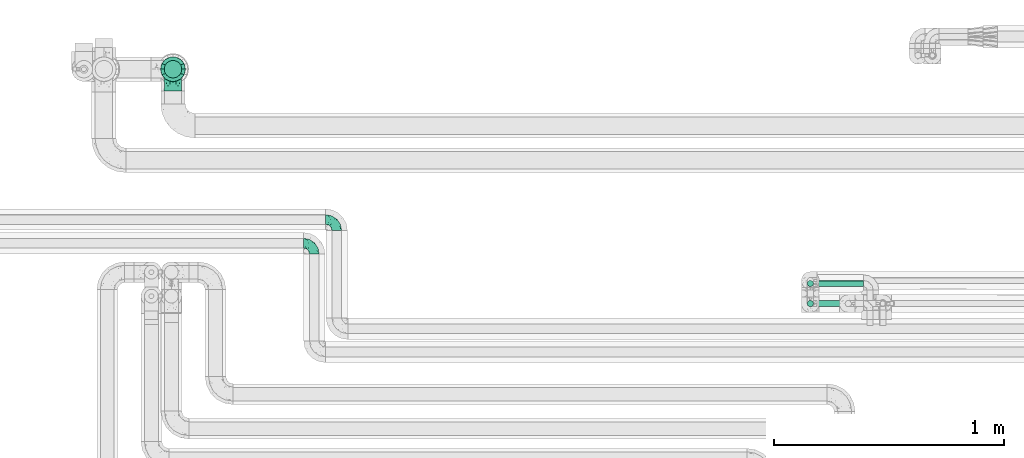
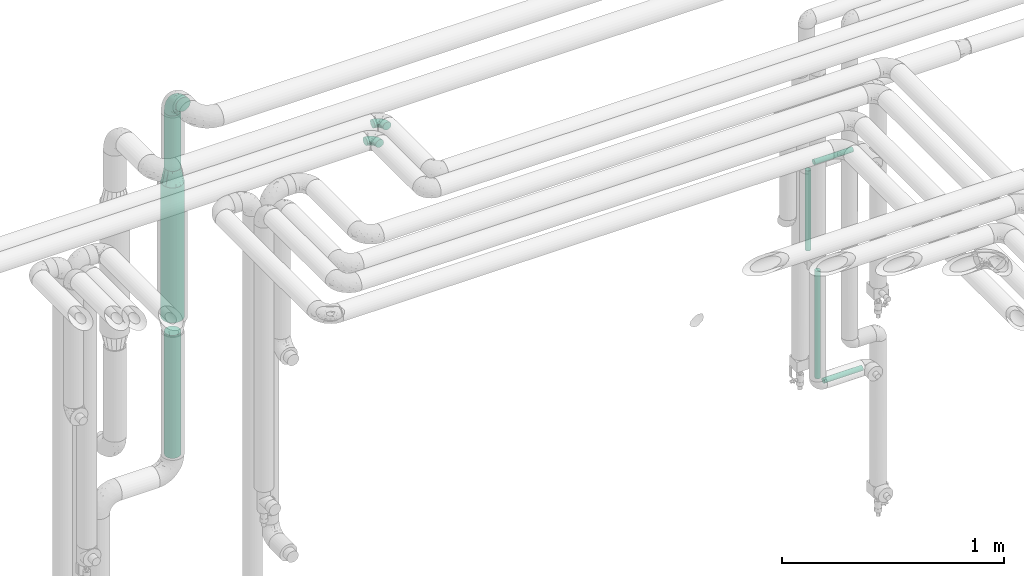
# One storey, part 644 of 827: 7 flow segments, 4 flow fittings.
"""IFC2X3 building model written with IfcOpenShell, lengths in millimetres."""

from ifc_helpers import new_model, entity, si_unit, converted_unit, derived_unit, direction, frame, origin, origin_2d_with_axis, place, context, subcontext, project, spatial, circle, extrude, faceted_brep, source, transform, mapped, material, type_object, type_shapes, element, save


model = new_model("IFC2X3")

# Units and contexts
model_context = context("Model", 3, precision=0.01, world=origin(), true_north=direction((6.12303176911189e-17, 1.0)))
body_context = subcontext(model_context, "Body", "Model", "MODEL_VIEW")
ifc_project = project(units=[si_unit("LENGTHUNIT", "METRE", prefix="MILLI"), si_unit("AREAUNIT", "SQUARE_METRE"), si_unit("VOLUMEUNIT", "CUBIC_METRE"), converted_unit("PLANEANGLEUNIT", "DEGREE", entity("IfcRatioMeasure", 0.0174532925199433), si_unit("PLANEANGLEUNIT", "RADIAN"), dimensions=[0, 0, 0, 0, 0, 0, 0]), si_unit("MASSUNIT", "GRAM", prefix="KILO"), derived_unit("MASSDENSITYUNIT", [(si_unit("MASSUNIT", "GRAM", prefix="KILO"), 1), (si_unit("LENGTHUNIT", "METRE"), -3)]), derived_unit("MOMENTOFINERTIAUNIT", [(si_unit("LENGTHUNIT", "METRE"), 4)]), si_unit("TIMEUNIT", "SECOND"), si_unit("FREQUENCYUNIT", "HERTZ"), si_unit("THERMODYNAMICTEMPERATUREUNIT", "DEGREE_CELSIUS"), derived_unit("THERMALTRANSMITTANCEUNIT", [(si_unit("MASSUNIT", "GRAM", prefix="KILO"), 1), (si_unit("THERMODYNAMICTEMPERATUREUNIT", "KELVIN"), -1), (si_unit("TIMEUNIT", "SECOND"), -3)]), derived_unit("VOLUMETRICFLOWRATEUNIT", [(si_unit("LENGTHUNIT", "METRE"), 3), (si_unit("TIMEUNIT", "SECOND"), -1)]), derived_unit("MASSFLOWRATEUNIT", [(si_unit("MASSUNIT", "GRAM", prefix="KILO"), 1), (si_unit("TIMEUNIT", "SECOND"), -1)]), derived_unit("ROTATIONALFREQUENCYUNIT", [(si_unit("TIMEUNIT", "SECOND"), -1)]), si_unit("ELECTRICCURRENTUNIT", "AMPERE"), si_unit("ELECTRICVOLTAGEUNIT", "VOLT"), si_unit("POWERUNIT", "WATT"), si_unit("FORCEUNIT", "NEWTON", prefix="KILO"), si_unit("ILLUMINANCEUNIT", "LUX"), si_unit("LUMINOUSFLUXUNIT", "LUMEN"), si_unit("LUMINOUSINTENSITYUNIT", "CANDELA"), derived_unit("USERDEFINED", [(si_unit("MASSUNIT", "GRAM", prefix="KILO"), -1), (si_unit("LENGTHUNIT", "METRE"), -2), (si_unit("TIMEUNIT", "SECOND"), 3), (si_unit("LUMINOUSFLUXUNIT", "LUMEN"), 1)]), derived_unit("LINEARVELOCITYUNIT", [(si_unit("LENGTHUNIT", "METRE"), 1), (si_unit("TIMEUNIT", "SECOND"), -1)]), si_unit("PRESSUREUNIT", "PASCAL"), derived_unit("USERDEFINED", [(si_unit("LENGTHUNIT", "METRE"), -2), (si_unit("MASSUNIT", "GRAM", prefix="KILO"), 1), (si_unit("TIMEUNIT", "SECOND"), -2)]), derived_unit("LINEARFORCEUNIT", [(si_unit("MASSUNIT", "GRAM", prefix="KILO"), 1), (si_unit("LENGTHUNIT", "METRE"), 1), (si_unit("TIMEUNIT", "SECOND"), -2), (si_unit("LENGTHUNIT", "METRE"), -1)]), derived_unit("PLANARFORCEUNIT", [(si_unit("MASSUNIT", "GRAM", prefix="KILO"), 1), (si_unit("LENGTHUNIT", "METRE"), 1), (si_unit("TIMEUNIT", "SECOND"), -2), (si_unit("LENGTHUNIT", "METRE"), -2)])], contexts=[model_context])

# Site, building, storey
site_placement = place(None, origin())
site = spatial("IfcSite", under=ifc_project, at=site_placement, CompositionType="ELEMENT")
building_placement = place(site_placement, origin())
building = spatial("IfcBuilding", under=site, at=building_placement, CompositionType="ELEMENT")
storey_placement = place(building_placement, frame((0.0, 0.0, 28200.0)))
storey = spatial("IfcBuildingStorey", under=building, at=storey_placement, Name="08", CompositionType="ELEMENT", Elevation=28200.0)

# Flow segments
pipe_segment_type_1 = type_object("IfcPipeSegmentType", PredefinedType="NOTDEFINED")
flow_segment_1_placement = place(storey_placement, frame((31716.11, 19313.84, 2600.0)))
element("IfcFlowSegment", 1, at=flow_segment_1_placement, inside=storey, type_object=pipe_segment_type_1, context=body_context, shape_type="SweptSolid", body=[
    extrude(circle(Radius=38.0, at=origin_2d_with_axis()), frame((39.6, 39.6, 0.0)), (0.0, 0.0, 1.0), 305.000000000013),
])
flow_segment_2_placement = place(storey_placement, frame((31716.31, 19313.84, 1020.26)))
element("IfcFlowSegment", 2, at=flow_segment_2_placement, inside=storey, type_object=pipe_segment_type_1, context=body_context, shape_type="SweptSolid", body=[
    extrude(circle(Radius=38.0, at=origin_2d_with_axis()), frame((39.6, 39.6, 0.0), z_axis=(0.0, 0.0, 1.0), x_axis=(-1.0, 0.0, 0.0)), (0.0, 0.0, 1.0), 676.738359999959),
])
flow_segment_3_placement = place(storey_placement, frame((31700.11, 19297.84, 1777.0)))
element("IfcFlowSegment", 3, at=flow_segment_3_placement, inside=storey, type_object=pipe_segment_type_1, context=body_context, shape_type="SweptSolid", body=[
    extrude(circle(Radius=54.0, at=origin_2d_with_axis()), frame((55.6, 55.6, 0.0), z_axis=(0.0, 0.0, 1.0), x_axis=(-1.0, 0.0, 0.0)), (0.0, 0.0, 1.0), 743.000000000004),
])
pipe_segment_type_2 = type_object("IfcPipeSegmentType", PredefinedType="NOTDEFINED")
flow_segment_4_placement = place(storey_placement, frame((34510.39, 18319.92, 1089.1)))
element("IfcFlowSegment", 4, at=flow_segment_4_placement, inside=storey, type_object=pipe_segment_type_2, context=body_context, shape_type="SweptSolid", body=[
    extrude(circle(Radius=13.4, at=origin_2d_with_axis()), frame((15.0, 15.0, 0.0)), (0.0, 0.0, 1.0), 591.900000000008),
])
flow_segment_5_placement = place(storey_placement, frame((34554.49, 18319.92, 1045.0)))
element("IfcFlowSegment", 5, at=flow_segment_5_placement, inside=storey, type_object=pipe_segment_type_2, context=body_context, shape_type="SweptSolid", body=[
    extrude(circle(Radius=13.4, at=origin_2d_with_axis()), frame((0.0, 15.0, 15.0), z_axis=(1.0, 0.0, 0.0), x_axis=(0.0, -1.0, 0.0)), (0.0, 0.0, 1.0), 201.799999999997),
])
flow_segment_6_placement = place(storey_placement, frame((34554.49, 18406.91, 2195.0)))
element("IfcFlowSegment", 6, at=flow_segment_6_placement, inside=storey, type_object=pipe_segment_type_2, context=body_context, shape_type="SweptSolid", body=[
    extrude(circle(Radius=13.4, at=origin_2d_with_axis()), frame((0.0, 15.0, 15.0), z_axis=(1.0, 0.0, 0.0), x_axis=(0.0, 1.0, 0.0)), (0.0, 0.0, 1.0), 201.799999999997),
])
flow_segment_7_placement = place(storey_placement, frame((34510.39, 18406.91, 1739.1)))
element("IfcFlowSegment", 7, at=flow_segment_7_placement, inside=storey, type_object=pipe_segment_type_2, context=body_context, shape_type="SweptSolid", body=[
    extrude(circle(Radius=13.4, at=origin_2d_with_axis()), frame((15.0, 15.0, 0.0)), (0.0, 0.0, 1.0), 441.800000000021),
])

# Flow fittings
ifc_material = material()
pipe_fitting_type_1 = type_object("IfcPipeFittingType", Name="ADSK_1", PredefinedType="NOTDEFINED", material=ifc_material)
shared_shape_1 = source(origin(), body_context, "Body", "Brep", [
    faceted_brep([(-48.0, 10.6, -18.36), (-48.0, 5.49, -20.48), (-48.0, 0.0, -21.2), (-48.0, -5.49, -20.48), (-48.0, -10.6, -18.36), (-48.0, -14.99, -14.99), (-48.0, -18.36, -10.6), (-48.0, -20.48, -5.49), (-48.0, -21.2, 0.0), (-48.0, -20.48, 5.49), (-48.0, -18.36, 10.6), (-48.0, -14.99, 14.99), (-48.0, -10.6, 18.36), (-48.0, -5.49, 20.48), (-48.0, 0.0, 21.2), (-48.0, 5.49, 20.48), (-48.0, 10.6, 18.36), (-48.0, 14.99, 14.99), (-48.0, 18.36, 10.6), (-48.0, 20.48, 5.49), (-48.0, 21.2, 0.0), (-48.0, 20.48, -5.49), (-48.0, 18.36, -10.6), (-48.0, 14.99, -14.99), (0.0, 48.0, -21.2), (-5.49, 48.0, -20.48), (-10.6, 48.0, -18.36), (-14.99, 48.0, -14.99), (-18.36, 48.0, -10.6), (-20.48, 48.0, -5.49), (-21.2, 48.0, 0.0), (-20.48, 48.0, 5.49), (-18.36, 48.0, 10.6), (-14.99, 48.0, 14.99), (-10.6, 48.0, 18.36), (-5.49, 48.0, 20.48), (0.0, 48.0, 21.2), (5.49, 48.0, 20.48), (10.6, 48.0, 18.36), (14.99, 48.0, 14.99), (18.36, 48.0, 10.6), (20.48, 48.0, 5.49), (21.2, 48.0, 0.0), (20.48, 48.0, -5.49), (18.36, 48.0, -10.6), (14.99, 48.0, -14.99), (10.6, 48.0, -18.36), (5.49, 48.0, -20.48), (-35.25, -16.22, 12.01), (-34.76, -18.57, 0.0), (-20.87, -12.37, 10.9), (-31.49, -11.78, 15.9), (-37.0, -2.58, 20.86), (-33.89, 3.62, 21.15), (-31.81, -18.14, 6.76), (-5.78, 5.78, 17.67), (-19.42, -4.1, 17.86), (-9.6, -3.39, 13.73), (-35.44, -7.73, 19.13), (11.78, 31.49, 15.9), (-5.93, -5.46, 6.95), (-18.45, -13.78, 5.46), (-10.29, -8.43, 0.0), (-24.6, 0.55, 20.62), (-37.28, 17.94, 13.81), (-33.38, 22.85, 9.59), (-41.46, 20.06, 8.75), (-29.51, 20.45, 15.16), (-15.04, 10.79, 21.13), (-7.08, 16.98, 20.93), (-8.39, 23.51, 21.15), (-40.86, 13.03, 17.26), (-8.05, 41.26, 19.83), (-3.21, 35.97, 21.14), (8.53, 19.66, 14.74), (4.1, 19.42, 17.86), (-37.72, 22.66, 4.78), (-37.07, 8.58, 19.98), (-13.0, 5.43, 19.97), (-3.78, 13.93, 19.7), (3.02, 8.69, 13.43), (-2.27, -0.05, 10.65), (6.22, 6.99, 7.09), (-22.25, 34.6, 9.45), (18.14, 31.81, 6.76), (16.22, 35.25, 12.01), (12.37, 20.87, 10.9), (7.73, 35.44, 19.13), (-21.52, -15.93, 0.0), (2.58, 37.0, 20.86), (18.57, 34.76, 0.0), (13.78, 18.45, 5.46), (15.93, 21.52, 0.0), (-20.03, -8.54, 14.9), (-28.6, 28.6, 5.16), (-24.79, 34.6, 0.0), (-34.6, 24.79, 0.0), (-22.81, 37.41, 4.68), (-23.36, 26.33, 14.79), (-13.68, 37.05, 17.49), (-17.72, 38.12, 13.73), (-26.25, 27.3, 11.24), (-9.71, 32.34, 20.14), (-17.26, 25.6, 18.71), (-26.33, 9.99, 20.77), (-24.06, 6.05, 21.2), (-25.02, 15.46, 19.56), (-24.3, 20.72, 17.57), (-31.95, 15.23, 17.8), (-13.53, 24.7, 20.21), (-17.6, 17.6, 20.6), (-0.55, 24.6, 20.62), (-11.41, -7.48, 10.43), (0.93, -0.93, 0.0), (8.43, 10.29, 0.0), (-11.41, -7.48, -10.43), (-20.1, -8.84, -14.66), (-9.6, -3.39, -13.73), (7.73, 35.44, -19.13), (4.1, 19.42, -17.86), (-0.55, 24.6, -20.62), (-38.12, 17.72, -13.73), (-37.05, 13.68, -17.49), (-32.34, 9.71, -20.14), (-41.26, 8.05, -19.83), (-37.41, 22.81, -4.68), (-23.51, 8.39, -21.15), (-35.97, 3.21, -21.14), (-28.6, 28.6, -5.16), (-31.81, -18.14, -6.76), (-18.45, -13.78, -5.46), (-25.6, 17.26, -18.71), (-19.42, -4.1, -17.86), (-17.94, 37.28, -13.81), (-22.85, 33.38, -9.59), (-20.06, 41.46, -8.75), (-31.49, -11.78, -15.9), (-35.25, -16.22, -12.01), (8.53, 19.66, -14.74), (11.78, 31.49, -15.9), (-9.99, 26.33, -20.77), (-6.05, 24.06, -21.2), (-10.79, 15.04, -21.13), (-37.0, -2.58, -20.86), (-16.98, 7.08, -20.93), (-5.43, 13.0, -19.97), (-13.93, 3.78, -19.7), (-20.87, -12.37, -10.9), (-26.33, 23.36, -14.79), (-22.66, 37.72, -4.78), (13.78, 18.45, -5.46), (18.14, 31.81, -6.76), (-15.46, 25.02, -19.56), (-20.72, 24.3, -17.57), (16.22, 35.25, -12.01), (-13.03, 40.86, -17.26), (-8.58, 37.07, -19.98), (2.58, 37.0, -20.86), (-3.62, 33.89, -21.15), (-34.6, 22.25, -9.45), (6.22, 6.99, -7.09), (-20.45, 29.51, -15.16), (-35.44, -7.73, -19.13), (12.37, 20.87, -10.9), (-27.3, 26.25, -11.24), (-15.23, 31.95, -17.8), (-24.7, 13.53, -20.21), (-24.6, 0.55, -20.62), (-5.78, 5.78, -17.67), (-17.6, 17.6, -20.6), (3.02, 8.69, -13.43), (-5.93, -5.46, -6.95), (-2.27, -0.05, -10.65)], [[[0, 1, 2, 3, 4, 5, 6, 7, 8, 9, 10, 11, 12, 13, 14, 15, 16, 17, 18, 19, 20, 21, 22, 23]], [[24, 25, 26, 27, 28, 29, 30, 31, 32, 33, 34, 35, 36, 37, 38, 39, 40, 41, 42, 43, 44, 45, 46, 47]], [[10, 48, 11]], [[9, 8, 49]], [[48, 50, 51]], [[14, 52, 53]], [[10, 54, 48]], [[9, 54, 10]], [[55, 56, 57]], [[51, 12, 11]], [[51, 58, 12]], [[59, 39, 38]], [[60, 61, 62]], [[58, 56, 63]], [[64, 65, 66]], [[67, 65, 64]], [[68, 69, 70]], [[16, 71, 17]], [[13, 52, 14]], [[35, 72, 73]], [[14, 53, 15]], [[17, 64, 18]], [[74, 59, 75]], [[20, 19, 76]], [[66, 19, 18]], [[77, 15, 53]], [[15, 77, 16]], [[69, 78, 79]], [[80, 81, 82]], [[32, 31, 83]], [[84, 85, 86]], [[59, 87, 75]], [[61, 54, 88]], [[36, 89, 37]], [[84, 41, 40]], [[36, 35, 73]], [[90, 41, 84]], [[40, 39, 85]], [[12, 58, 13]], [[85, 84, 40]], [[91, 84, 86]], [[84, 92, 90]], [[87, 38, 37]], [[93, 56, 51]], [[65, 94, 76]], [[94, 95, 96]], [[84, 91, 92]], [[95, 97, 30]], [[98, 99, 100]], [[76, 94, 96]], [[101, 98, 83]], [[100, 99, 33]], [[102, 70, 73]], [[103, 102, 99]], [[94, 97, 95]], [[72, 99, 102]], [[72, 35, 34]], [[34, 33, 99]], [[9, 49, 54]], [[87, 59, 38]], [[104, 105, 68]], [[106, 103, 107]], [[106, 77, 104]], [[71, 64, 17]], [[108, 107, 67]], [[33, 32, 100]], [[109, 103, 110]], [[102, 109, 70]], [[89, 73, 111]], [[50, 48, 54]], [[51, 11, 48]], [[56, 58, 51]], [[88, 54, 49]], [[52, 58, 63]], [[50, 112, 93]], [[56, 55, 78]], [[39, 59, 85]], [[86, 85, 59]], [[89, 87, 37]], [[42, 41, 90]], [[111, 79, 75]], [[111, 75, 87]], [[75, 55, 80]], [[104, 77, 53]], [[71, 77, 108]], [[32, 83, 100]], [[98, 100, 83]], [[99, 98, 103]], [[106, 107, 108]], [[68, 70, 110]], [[111, 73, 70]], [[68, 110, 104]], [[68, 63, 78]], [[57, 93, 112]], [[80, 55, 57]], [[61, 50, 54]], [[80, 82, 86]], [[81, 57, 112]], [[74, 86, 59]], [[60, 113, 82]], [[82, 114, 91]], [[101, 94, 65]], [[97, 94, 83]], [[73, 89, 36]], [[87, 89, 111]], [[58, 52, 13]], [[53, 52, 63]], [[104, 53, 105]], [[106, 104, 110]], [[20, 76, 96]], [[76, 19, 66]], [[103, 106, 110]], [[77, 106, 108]], [[103, 98, 107]], [[67, 107, 98]], [[67, 98, 101]], [[108, 67, 64]], [[53, 63, 105]], [[63, 68, 105]], [[83, 31, 97]], [[30, 97, 31]], [[62, 113, 60]], [[112, 61, 60]], [[61, 88, 62]], [[86, 82, 91]], [[56, 78, 63]], [[114, 82, 113]], [[114, 92, 91]], [[79, 78, 55]], [[75, 79, 55]], [[69, 79, 111]], [[70, 69, 111]], [[78, 69, 68]], [[77, 71, 16]], [[64, 71, 108]], [[64, 66, 18]], [[76, 66, 65]], [[99, 72, 34]], [[73, 72, 102]], [[94, 101, 83]], [[67, 101, 65]], [[75, 80, 74]], [[80, 86, 74]], [[70, 109, 110]], [[102, 103, 109]], [[50, 93, 51]], [[57, 56, 93]], [[61, 112, 50]], [[81, 112, 60]], [[82, 81, 60]], [[80, 57, 81]], [[115, 116, 117]], [[118, 119, 120]], [[121, 122, 23]], [[123, 124, 122]], [[96, 125, 20]], [[123, 126, 127]], [[128, 96, 95]], [[129, 130, 88]], [[123, 122, 131]], [[116, 132, 117]], [[133, 134, 135]], [[0, 124, 1]], [[5, 136, 137]], [[138, 119, 139]], [[129, 88, 49]], [[140, 141, 142]], [[6, 5, 137]], [[46, 118, 47]], [[143, 3, 2]], [[144, 145, 146]], [[6, 129, 7]], [[129, 137, 147]], [[127, 2, 1]], [[148, 122, 121]], [[128, 125, 96]], [[134, 128, 149]], [[95, 149, 128]], [[150, 151, 92]], [[30, 29, 149]], [[152, 131, 153]], [[27, 133, 28]], [[154, 45, 44]], [[136, 5, 4]], [[27, 26, 155]], [[156, 26, 25]], [[24, 157, 158]], [[24, 47, 157]], [[22, 21, 159]], [[160, 150, 114]], [[134, 133, 161]], [[142, 144, 126]], [[46, 139, 118]], [[162, 136, 4]], [[156, 25, 158]], [[1, 124, 127]], [[115, 147, 116]], [[45, 154, 139]], [[139, 46, 45]], [[154, 163, 139]], [[162, 4, 3]], [[42, 90, 43]], [[130, 129, 147]], [[49, 7, 129]], [[43, 151, 44]], [[0, 23, 122]], [[24, 158, 25]], [[136, 162, 132]], [[135, 29, 28]], [[43, 90, 151]], [[164, 148, 159]], [[152, 156, 140]], [[155, 133, 27]], [[165, 153, 161]], [[23, 22, 121]], [[123, 131, 166]], [[123, 166, 126]], [[143, 127, 167]], [[147, 137, 136]], [[8, 7, 49]], [[129, 6, 137]], [[143, 162, 3]], [[167, 146, 132]], [[167, 132, 162]], [[132, 168, 117]], [[44, 151, 154]], [[92, 151, 90]], [[163, 154, 151]], [[119, 118, 139]], [[157, 118, 120]], [[138, 139, 163]], [[119, 168, 145]], [[140, 156, 158]], [[155, 156, 165]], [[22, 159, 121]], [[148, 121, 159]], [[122, 148, 131]], [[152, 153, 165]], [[142, 126, 169]], [[167, 127, 126]], [[142, 169, 140]], [[142, 120, 145]], [[168, 170, 117]], [[160, 171, 172]], [[115, 172, 171]], [[171, 62, 130]], [[119, 170, 168]], [[170, 163, 160]], [[150, 163, 151]], [[113, 171, 160]], [[164, 128, 134]], [[125, 128, 159]], [[127, 143, 2]], [[162, 143, 167]], [[118, 157, 47]], [[158, 157, 120]], [[140, 158, 141]], [[152, 140, 169]], [[30, 149, 95]], [[149, 29, 135]], [[131, 152, 169]], [[156, 152, 165]], [[131, 148, 153]], [[161, 153, 148]], [[161, 148, 164]], [[165, 161, 133]], [[158, 120, 141]], [[120, 142, 141]], [[159, 21, 125]], [[20, 125, 21]], [[115, 130, 147]], [[114, 113, 160]], [[62, 171, 113]], [[62, 88, 130]], [[160, 163, 150]], [[150, 92, 114]], [[119, 145, 120]], [[146, 145, 168]], [[132, 146, 168]], [[144, 146, 167]], [[126, 144, 167]], [[145, 144, 142]], [[156, 155, 26]], [[133, 155, 165]], [[133, 135, 28]], [[149, 135, 134]], [[122, 124, 0]], [[127, 124, 123]], [[128, 164, 159]], [[161, 164, 134]], [[163, 170, 138]], [[170, 119, 138]], [[131, 169, 166]], [[126, 166, 169]], [[147, 136, 116]], [[132, 116, 136]], [[172, 115, 117]], [[130, 115, 171]], [[117, 170, 172]], [[160, 172, 170]]]),
])
type_shapes(pipe_fitting_type_1, [shared_shape_1])
for number, where, z_axis, x_axis, name in (
    (8, (32370.03, 18597.5, 2999.5), (0.0, 0.0, 1.0), (0.0, 1.0, 0.0), "ADSK_1"),
    (9, (32467.53, 18700.0, 2999.91), (0.0, 0.0, 1.0), (0.0, 1.0, 0.0), "ADSK_1"),
):
    element("IfcFlowFitting", number, at=place(storey_placement, frame(where, z_axis=z_axis, x_axis=x_axis)), inside=storey, type_object=pipe_fitting_type_1, material=ifc_material, Name=name, ObjectType="ADSK_1", context=body_context, shape_type="MappedRepresentation", body=[
        mapped(shared_shape_1, transform((0.0, 0.0, 0.0), scale=1.0)),
    ])
pipe_fitting_type_2 = type_object("IfcPipeFittingType", Name="ADSK_1", PredefinedType="NOTDEFINED", material=ifc_material)
shared_shape_2 = source(origin(), body_context, "Body", "Brep", [
    faceted_brep([(-95.0, 19.02, -32.95), (-95.0, 9.85, -36.75), (-95.0, 0.0, -38.05), (-95.0, -9.85, -36.75), (-95.0, -19.03, -32.95), (-95.0, -26.91, -26.91), (-95.0, -32.95, -19.03), (-95.0, -36.75, -9.85), (-95.0, -38.05, 0.0), (-95.0, -36.75, 9.85), (-95.0, -32.95, 19.02), (-95.0, -26.91, 26.91), (-95.0, -19.03, 32.95), (-95.0, -9.85, 36.75), (-95.0, 0.0, 38.05), (-95.0, 9.85, 36.75), (-95.0, 19.02, 32.95), (-95.0, 26.91, 26.91), (-95.0, 32.95, 19.02), (-95.0, 36.75, 9.85), (-95.0, 38.05, 0.0), (-95.0, 36.75, -9.85), (-95.0, 32.95, -19.03), (-95.0, 26.91, -26.91), (0.0, 95.0, -38.05), (-9.85, 95.0, -36.75), (-19.02, 95.0, -32.95), (-26.91, 95.0, -26.91), (-32.95, 95.0, -19.03), (-36.75, 95.0, -9.85), (-38.05, 95.0, 0.0), (-36.75, 95.0, 9.85), (-32.95, 95.0, 19.02), (-26.91, 95.0, 26.91), (-19.02, 95.0, 32.95), (-9.85, 95.0, 36.75), (0.0, 95.0, 38.05), (9.85, 95.0, 36.75), (19.03, 95.0, 32.95), (26.91, 95.0, 26.91), (32.95, 95.0, 19.02), (36.75, 95.0, 9.85), (38.05, 95.0, 0.0), (36.75, 95.0, -9.85), (32.95, 95.0, -19.03), (26.91, 95.0, -26.91), (19.03, 95.0, -32.95), (9.85, 95.0, -36.75), (-7.99, -4.96, 6.3), (-0.92, 0.92, 0.0), (4.62, 8.1, 8.01), (-76.19, -35.57, 0.0), (-64.32, -32.32, 12.43), (20.51, 62.45, 28.68), (-60.56, -33.52, 0.0), (-70.4, -13.47, 34.42), (-39.61, -5.88, 32.32), (-49.6, 2.07, 37.1), (-70.34, -28.81, 21.71), (14.64, 40.81, 26.5), (5.88, 39.61, 32.32), (3.59, 20.77, 25.31), (-40.45, 68.06, 16.75), (-62.45, -20.51, 28.68), (-44.52, -26.87, 0.0), (-28.47, -20.22, 0.0), (-26.43, -17.83, 8.75), (-76.1, 39.63, 10.76), (-72.74, 37.58, 18.19), (-60.35, 46.18, 14.61), (-13.4, 13.4, 32.12), (-20.77, -3.59, 25.31), (-14.66, 81.47, 35.56), (-6.22, 71.26, 37.92), (-57.5, 42.48, 22.79), (-15.0, 34.74, 37.7), (-27.1, 12.08, 36.05), (-9.2, 28.81, 35.63), (-79.98, 23.7, 30.95), (-73.68, -4.3, 37.48), (-30.74, 21.67, 37.97), (-62.36, 47.59, 6.79), (-72.71, 32.83, 24.69), (-67.42, 7.02, 37.95), (-32.13, 75.27, 24.51), (-43.46, 51.47, 26.26), (-24.98, 73.15, 31.29), (20.59, 41.28, 19.85), (7.79, 16.09, 15.86), (-73.21, 42.39, 0.0), (-54.73, 54.73, 0.0), (-73.44, 15.79, 35.79), (-5.94, 4.32, 20.43), (28.81, 70.34, 21.71), (32.32, 64.32, 12.43), (-53.59, 26.2, 35.09), (-52.02, 19.31, 37.21), (21.38, 33.53, 10.34), (26.87, 44.52, 0.0), (-48.28, 12.14, 38.05), (4.3, 73.68, 37.48), (-44.08, -25.52, 12.79), (-41.28, -20.59, 19.85), (35.57, 76.19, 0.0), (-47.26, 54.3, 20.18), (-47.4, 61.99, 8.58), (-42.39, 73.21, 0.0), (-39.67, 78.86, 7.21), (-45.69, 36.84, 33.11), (-32.83, 50.13, 33.35), (13.47, 70.4, 34.42), (-18.25, 63.73, 36.07), (-40.63, -13.75, 27.22), (-16.63, 46.37, 37.95), (-53.47, 38.79, 28.59), (-26.07, 48.54, 36.15), (-34.51, 34.51, 36.86), (-2.07, 49.6, 37.1), (-22.79, -10.49, 19.23), (-61.73, 28.67, 31.87), (9.65, 14.7, 0.0), (20.22, 28.47, 0.0), (33.52, 60.56, 0.0), (-11.42, -5.44, 13.25), (-14.7, -9.65, 0.0), (-81.47, 14.66, -35.56), (-62.45, -20.51, -28.68), (-71.26, 6.22, -37.92), (-75.27, 32.13, -24.51), (-73.15, 24.98, -31.29), (13.47, 70.4, -34.42), (5.88, 39.61, -32.32), (-2.07, 49.6, -37.1), (-78.86, 39.67, -7.21), (-70.4, -13.47, -34.42), (-39.61, -5.88, -32.32), (-61.99, 47.4, -8.58), (32.32, 64.32, -12.43), (28.81, 70.34, -21.71), (-63.73, 18.25, -36.07), (-50.13, 32.83, -33.35), (4.3, 73.68, -37.48), (-7.02, 67.42, -37.95), (-39.63, 76.1, -10.76), (-46.18, 60.35, -14.61), (-47.59, 62.36, -6.79), (-64.32, -32.32, -12.43), (-26.2, 53.59, -35.09), (-15.79, 73.44, -35.79), (-19.31, 52.02, -37.21), (-37.58, 72.74, -18.19), (-70.34, -28.81, -21.71), (-42.48, 57.5, -22.79), (-38.79, 53.47, -28.59), (-51.47, 43.46, -26.26), (-32.83, 72.71, -24.69), (-46.37, 16.63, -37.95), (-73.68, -4.3, -37.48), (-41.28, -20.59, -19.85), (-44.08, -25.52, -12.79), (13.75, 40.63, -27.22), (20.51, 62.45, -28.68), (-68.06, 40.45, -16.75), (-54.3, 47.26, -20.18), (-12.14, 48.28, -38.05), (-21.67, 30.74, -37.97), (-36.84, 45.69, -33.11), (-11.42, -5.44, -13.25), (7.79, 16.09, -15.86), (4.62, 8.1, -8.01), (-23.7, 79.98, -30.95), (-26.43, -17.83, -8.75), (-7.99, -4.96, -6.3), (-40.81, -14.64, -26.5), (-20.77, -3.59, -25.31), (-34.74, 15.0, -37.7), (-12.08, 27.1, -36.05), (-28.81, 9.2, -35.63), (-22.79, -10.49, -19.23), (21.38, 33.53, -10.34), (20.59, 41.28, -19.85), (-48.54, 26.07, -36.15), (-49.6, 2.07, -37.1), (-13.4, 13.4, -32.12), (3.59, 20.77, -25.31), (-28.67, 61.73, -31.87), (-34.51, 34.51, -36.86), (-5.94, 4.32, -20.43)], [[[0, 1, 2, 3, 4, 5, 6, 7, 8, 9, 10, 11, 12, 13, 14, 15, 16, 17, 18, 19, 20, 21, 22, 23]], [[24, 25, 26, 27, 28, 29, 30, 31, 32, 33, 34, 35, 36, 37, 38, 39, 40, 41, 42, 43, 44, 45, 46, 47]], [[48, 49, 50]], [[51, 52, 9]], [[53, 39, 38]], [[9, 52, 10]], [[54, 52, 51]], [[55, 56, 57]], [[11, 10, 58]], [[59, 60, 61]], [[32, 31, 62]], [[63, 12, 11]], [[63, 55, 12]], [[64, 65, 66]], [[67, 68, 69]], [[70, 56, 71]], [[35, 72, 73]], [[69, 68, 74]], [[75, 76, 77]], [[16, 78, 17]], [[13, 79, 14]], [[76, 75, 80]], [[67, 69, 81]], [[18, 17, 82]], [[14, 79, 83]], [[20, 19, 67]], [[84, 85, 86]], [[87, 61, 88]], [[89, 81, 90]], [[18, 82, 68]], [[15, 91, 16]], [[14, 83, 15]], [[71, 92, 61]], [[17, 78, 82]], [[93, 87, 94]], [[95, 91, 96]], [[97, 98, 94]], [[86, 72, 34]], [[96, 99, 80]], [[37, 36, 100]], [[40, 39, 93]], [[40, 94, 41]], [[64, 66, 101]], [[93, 94, 40]], [[58, 102, 63]], [[94, 103, 41]], [[94, 87, 97]], [[104, 69, 74]], [[34, 33, 86]], [[105, 69, 104]], [[52, 58, 10]], [[106, 107, 30]], [[108, 109, 85]], [[105, 106, 90]], [[53, 110, 60]], [[86, 111, 72]], [[86, 109, 111]], [[33, 84, 86]], [[12, 55, 13]], [[112, 56, 63]], [[110, 38, 37]], [[34, 72, 35]], [[36, 35, 73]], [[111, 113, 73]], [[105, 107, 106]], [[110, 53, 38]], [[74, 114, 85]], [[91, 15, 83]], [[105, 90, 81]], [[107, 62, 31]], [[33, 32, 84]], [[115, 109, 116]], [[111, 115, 113]], [[100, 73, 117]], [[56, 55, 63]], [[79, 55, 57]], [[102, 118, 112]], [[56, 70, 76]], [[100, 110, 37]], [[117, 77, 60]], [[117, 60, 110]], [[60, 70, 61]], [[58, 52, 101]], [[63, 11, 58]], [[39, 53, 93]], [[87, 93, 53]], [[96, 91, 83]], [[78, 91, 119]], [[32, 62, 84]], [[84, 62, 104]], [[86, 85, 109]], [[85, 114, 108]], [[80, 113, 116]], [[117, 73, 113]], [[80, 116, 96]], [[80, 57, 76]], [[71, 112, 118]], [[61, 87, 59]], [[62, 107, 105]], [[97, 120, 121]], [[70, 71, 61]], [[71, 118, 92]], [[73, 100, 36]], [[110, 100, 117]], [[55, 79, 13]], [[83, 79, 57]], [[96, 83, 99]], [[116, 108, 95]], [[50, 97, 88]], [[97, 87, 88]], [[50, 49, 120]], [[122, 94, 98]], [[89, 20, 67]], [[105, 81, 69]], [[89, 67, 81]], [[68, 19, 18]], [[68, 67, 19]], [[74, 68, 82]], [[114, 82, 119]], [[74, 85, 104]], [[82, 114, 74]], [[114, 119, 108]], [[95, 108, 119]], [[116, 109, 108]], [[123, 48, 50]], [[97, 50, 120]], [[123, 50, 88]], [[91, 95, 119]], [[116, 95, 96]], [[84, 104, 85]], [[104, 62, 105]], [[83, 57, 99]], [[57, 80, 99]], [[66, 48, 123]], [[66, 124, 48]], [[118, 66, 123]], [[124, 66, 65]], [[66, 118, 101]], [[54, 64, 52]], [[124, 49, 48]], [[30, 107, 31]], [[91, 78, 16]], [[82, 78, 119]], [[56, 76, 57]], [[77, 76, 70]], [[60, 77, 70]], [[77, 117, 75]], [[117, 113, 75]], [[113, 80, 75]], [[9, 8, 51]], [[103, 94, 122]], [[103, 42, 41]], [[73, 72, 111]], [[113, 115, 116]], [[111, 109, 115]], [[102, 112, 63]], [[71, 56, 112]], [[118, 102, 101]], [[92, 123, 88]], [[123, 92, 118]], [[61, 92, 88]], [[87, 53, 59]], [[60, 59, 53]], [[97, 121, 98]], [[58, 101, 102]], [[64, 101, 52]], [[125, 1, 0]], [[126, 5, 4]], [[2, 1, 127]], [[1, 125, 127]], [[128, 129, 23]], [[130, 131, 132]], [[89, 133, 20]], [[126, 134, 135]], [[136, 89, 90]], [[137, 138, 44]], [[139, 129, 140]], [[24, 141, 142]], [[143, 144, 145]], [[125, 129, 139]], [[6, 146, 7]], [[147, 148, 149]], [[146, 51, 7]], [[143, 150, 144]], [[146, 6, 151]], [[152, 153, 154]], [[126, 4, 134]], [[0, 23, 129]], [[28, 155, 150]], [[43, 42, 103]], [[54, 146, 64]], [[139, 156, 127]], [[157, 3, 2]], [[151, 158, 159]], [[160, 131, 161]], [[22, 21, 162]], [[136, 144, 163]], [[149, 164, 165]], [[24, 142, 25]], [[166, 140, 154]], [[154, 129, 128]], [[143, 30, 29]], [[167, 168, 169]], [[155, 28, 27]], [[26, 170, 27]], [[171, 167, 172]], [[26, 25, 148]], [[27, 170, 155]], [[173, 135, 174]], [[144, 150, 152]], [[175, 176, 177]], [[24, 47, 141]], [[45, 161, 46]], [[148, 25, 142]], [[176, 175, 165]], [[64, 159, 171]], [[138, 45, 44]], [[130, 46, 161]], [[137, 44, 43]], [[178, 159, 158]], [[137, 103, 122]], [[163, 144, 152]], [[136, 133, 89]], [[103, 137, 43]], [[6, 5, 151]], [[178, 158, 173]], [[134, 4, 3]], [[178, 173, 174]], [[137, 98, 179]], [[145, 90, 106]], [[138, 180, 161]], [[46, 130, 47]], [[136, 90, 145]], [[133, 162, 21]], [[23, 22, 128]], [[139, 140, 181]], [[139, 181, 156]], [[157, 127, 182]], [[157, 134, 3]], [[182, 177, 135]], [[182, 135, 134]], [[135, 183, 174]], [[131, 130, 161]], [[141, 130, 132]], [[160, 180, 184]], [[131, 183, 176]], [[5, 126, 151]], [[158, 151, 126]], [[180, 138, 137]], [[161, 45, 138]], [[149, 148, 142]], [[170, 148, 185]], [[22, 162, 128]], [[128, 162, 163]], [[129, 154, 140]], [[154, 153, 166]], [[165, 156, 186]], [[182, 127, 156]], [[165, 186, 149]], [[165, 132, 176]], [[131, 184, 183]], [[187, 167, 178]], [[184, 168, 187]], [[167, 169, 172]], [[184, 180, 168]], [[174, 183, 184]], [[127, 157, 2]], [[134, 157, 182]], [[130, 141, 47]], [[142, 141, 132]], [[149, 142, 164]], [[186, 166, 147]], [[180, 179, 168]], [[169, 179, 120]], [[137, 179, 180]], [[179, 121, 120]], [[106, 30, 143]], [[136, 145, 144]], [[106, 143, 145]], [[150, 29, 28]], [[150, 143, 29]], [[152, 150, 155]], [[153, 155, 185]], [[152, 154, 163]], [[155, 153, 152]], [[153, 185, 166]], [[147, 166, 185]], [[186, 140, 166]], [[169, 120, 49]], [[169, 49, 172]], [[179, 169, 168]], [[148, 147, 185]], [[186, 147, 149]], [[128, 163, 154]], [[163, 162, 136]], [[142, 132, 164]], [[132, 165, 164]], [[171, 124, 65]], [[124, 171, 172]], [[64, 146, 159]], [[171, 159, 178]], [[171, 65, 64]], [[172, 49, 124]], [[162, 133, 136]], [[20, 133, 21]], [[148, 170, 26]], [[155, 170, 185]], [[131, 176, 132]], [[177, 176, 183]], [[135, 177, 183]], [[177, 182, 175]], [[182, 156, 175]], [[156, 165, 175]], [[51, 146, 54]], [[51, 8, 7]], [[129, 125, 0]], [[127, 125, 139]], [[140, 186, 181]], [[156, 181, 186]], [[158, 126, 173]], [[135, 173, 126]], [[187, 178, 174]], [[171, 178, 167]], [[184, 187, 174]], [[167, 187, 168]], [[180, 160, 161]], [[184, 131, 160]], [[98, 137, 122]], [[98, 121, 179]], [[151, 159, 146]]]),
])
type_shapes(pipe_fitting_type_2, [shared_shape_2])
flow_fitting_1_placement = place(storey_placement, frame((31755.7, 19353.43, 3000.0), z_axis=(-1.0, 0.0, 0.0), x_axis=(0.0, 1.0, 0.0)))
element("IfcFlowFitting", 10, at=flow_fitting_1_placement, inside=storey, type_object=pipe_fitting_type_2, material=ifc_material, Name="ADSK_1", ObjectType="ADSK_1", context=body_context, shape_type="MappedRepresentation", body=[
    mapped(shared_shape_2, transform((0.0, 0.0, 0.0), scale=1.0)),
])
pipe_fitting_type_3 = type_object("IfcPipeFittingType", Name="ADSK_2", PredefinedType="NOTDEFINED", material=ifc_material)
shared_shape_3 = source(origin(), body_context, "Body", "Brep", [
    faceted_brep([(80.0, -19.0, 32.91), (80.0, -25.95, 25.95), (80.0, -32.91, 19.0), (80.0, -35.45, 9.5), (80.0, -38.0, 0.0), (80.0, -35.45, -9.5), (80.0, -32.91, -19.0), (80.0, -25.95, -25.95), (80.0, -19.0, -32.91), (80.0, -9.5, -35.45), (80.0, 0.0, -38.0), (80.0, 9.5, -35.45), (80.0, 19.0, -32.91), (80.0, 25.95, -25.95), (80.0, 32.91, -19.0), (80.0, 35.45, -9.5), (80.0, 38.0, 0.0), (80.0, 35.45, 9.5), (80.0, 32.91, 19.0), (80.0, 25.95, 25.95), (80.0, 19.0, 32.91), (80.0, 9.5, 35.45), (80.0, 0.0, 38.0), (80.0, -9.5, 35.45), (0.0, 22.84, 47.43), (0.0, 33.67, 42.22), (0.0, 41.16, 32.82), (0.0, 48.65, 23.43), (0.0, 51.33, 11.71), (0.0, 54.0, 0.0), (0.0, 51.33, -11.71), (0.0, 48.65, -23.43), (0.0, 41.16, -32.82), (0.0, 33.67, -42.22), (0.0, 22.84, -47.43), (0.0, 12.02, -52.65), (0.0, 0.0, -52.65), (0.0, -12.02, -52.65), (0.0, -22.84, -47.43), (0.0, -33.67, -42.22), (0.0, -41.16, -32.82), (0.0, -48.65, -23.43), (0.0, -51.33, -11.71), (0.0, -54.0, 0.0), (0.0, -51.33, 11.71), (0.0, -48.65, 23.43), (0.0, -41.16, 32.82), (0.0, -33.67, 42.22), (0.0, -22.84, 47.43), (0.0, -12.02, 52.65), (0.0, 0.0, 52.65), (0.0, 12.02, 52.65)], [[[0, 1, 2, 3, 4, 5, 6, 7, 8, 9, 10, 11, 12, 13, 14, 15, 16, 17, 18, 19, 20, 21, 22, 23]], [[24, 25, 26, 27, 28, 29, 30, 31, 32, 33, 34, 35, 36, 37, 38, 39, 40, 41, 42, 43, 44, 45, 46, 47, 48, 49, 50, 51]], [[15, 31, 30]], [[42, 4, 43]], [[32, 31, 14]], [[14, 31, 15]], [[34, 11, 35]], [[4, 42, 5]], [[13, 12, 33]], [[10, 37, 36, 35]], [[8, 39, 38]], [[39, 8, 7]], [[38, 9, 8]], [[34, 33, 12]], [[11, 10, 35]], [[40, 6, 41]], [[13, 33, 32]], [[16, 15, 30]], [[38, 37, 9]], [[16, 30, 29]], [[41, 6, 5]], [[6, 40, 7]], [[14, 13, 32]], [[11, 34, 12]], [[37, 10, 9]], [[40, 39, 7]], [[42, 41, 5]], [[3, 45, 44]], [[28, 16, 29]], [[46, 45, 2]], [[2, 45, 3]], [[48, 23, 49]], [[16, 28, 17]], [[1, 0, 47]], [[22, 51, 50, 49]], [[20, 25, 24]], [[25, 20, 19]], [[24, 21, 20]], [[48, 47, 0]], [[23, 22, 49]], [[26, 18, 27]], [[1, 47, 46]], [[4, 3, 44]], [[24, 51, 21]], [[4, 44, 43]], [[27, 18, 17]], [[18, 26, 19]], [[2, 1, 46]], [[23, 48, 0]], [[51, 22, 21]], [[26, 25, 19]], [[28, 27, 17]]]),
])
type_shapes(pipe_fitting_type_3, [shared_shape_3])
flow_fitting_2_placement = place(storey_placement, frame((31755.7, 19353.43, 2520.0), z_axis=(0.0, 1.0, 0.0), x_axis=(0.0, 0.0, 1.0)))
element("IfcFlowFitting", 11, at=flow_fitting_2_placement, inside=storey, type_object=pipe_fitting_type_3, material=ifc_material, Name="ADSK_2", ObjectType="ADSK_2", context=body_context, shape_type="MappedRepresentation", body=[
    mapped(shared_shape_3, transform((0.0, 0.0, 0.0), scale=1.0)),
])

save(model, "model.ifc")
